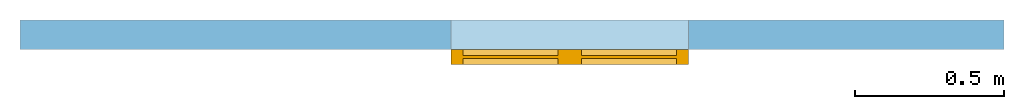
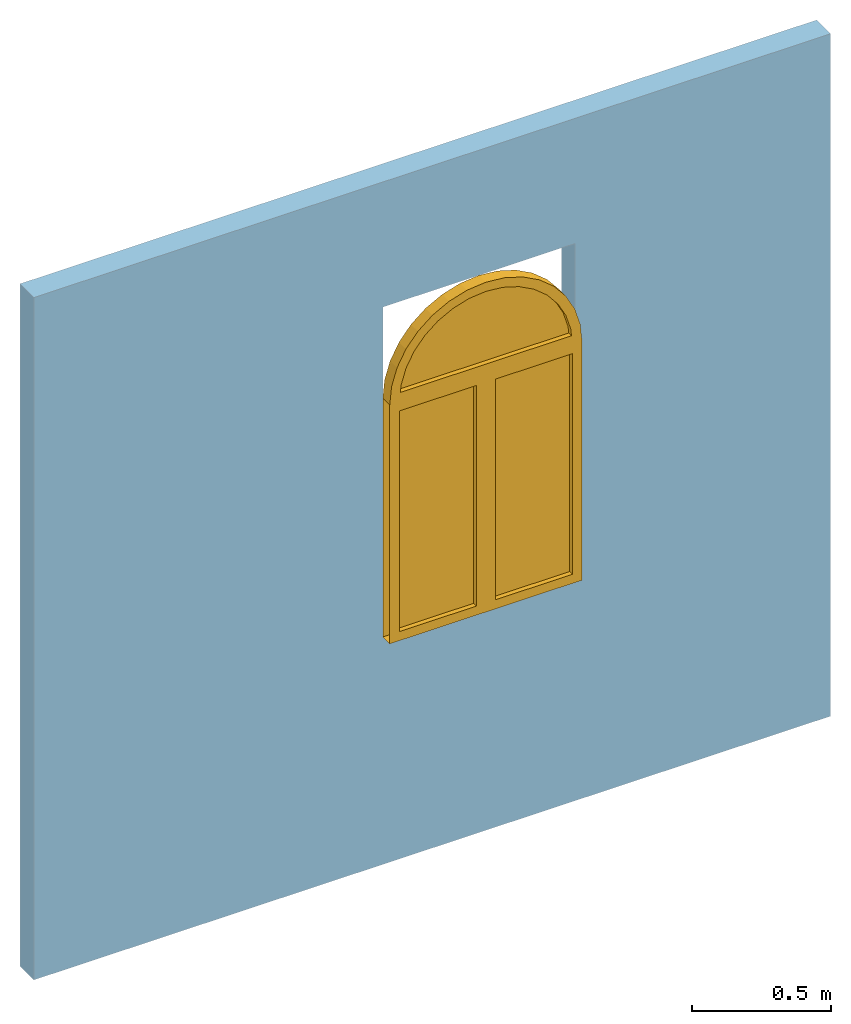
# One storey, part 2 of 2: 1 window, 1 opening, plus 1 element that does not belong to this part.
"""IFC4 building model written with IfcOpenShell, lengths in metres."""

from ifc_helpers import new_model, entity, si_unit, converted_unit, frame, origin_with_axes, origin_2d_with_axis, place, context, subcontext, project, spatial, line, indexed_curve, outline, extrude, polygons, source, transform, mapped, material, layer, layer_set, layer_usage, type_object, type_shapes, element, fill, save


model = new_model("IFC4")

# Units and contexts
model_context = context("Model", 3, precision=1e-05, world=origin_with_axes())
plan_context = context("Plan", 2, precision=1e-05, world=origin_2d_with_axis())
body_context = subcontext(model_context, "Body", "Model", "MODEL_VIEW")
ifc_project = project(units=[converted_unit("PLANEANGLEUNIT", "degree", entity("IfcReal", 0.0174532925199433), si_unit("PLANEANGLEUNIT", "RADIAN"), dimensions=[0, 0, 0, 0, 0, 0, 0]), si_unit("AREAUNIT", "SQUARE_METRE"), si_unit("VOLUMEUNIT", "CUBIC_METRE"), si_unit("LENGTHUNIT", "METRE")], contexts=[model_context, plan_context])

# Site, building, storey
site_placement = place(None, origin_with_axes())
site = spatial("IfcSite", under=ifc_project, at=site_placement)
building_placement = place(site_placement, origin_with_axes())
building = spatial("IfcBuilding", under=site, at=building_placement, Name="Building")
storey_placement = place(building_placement, origin_with_axes())
storey = spatial("IfcBuildingStorey", under=building, at=storey_placement, Name="Storey")

# Wall, opening, window
ifc_material = material()
ifc_layer = layer(ifc_material, 0.1)
ifc_layer_set = layer_set([ifc_layer])
ifc_layer_usage = layer_usage(ifc_layer_set, "AXIS2", "POSITIVE", 0.0)
wall_type = type_object("IfcWallType", PredefinedType="SOLIDWALL", material=ifc_layer_set)
wall_placement = place(storey_placement, origin_with_axes())
wall = element("IfcWall", 1, at=wall_placement, inside=storey, type_object=wall_type, material=ifc_layer_usage, Name="Wall", context=body_context, shape_type="SweptSolid", body=[
    extrude(outline(indexed_curve([(0.0, 0.0), (0.0, 0.1), (3.31257111095178, 0.1), (3.31257111095178, 0.0), (0.0, 0.0)], self_intersect=False)), origin_with_axes(), (0.0, 0.0, 1.0), 3.0),
])
shared_shape_1 = source(origin_with_axes(), body_context, "Body", "SweptSolid", [
    extrude(outline(indexed_curve([(0.0, 0.0), (0.799999833106995, 0.0), (0.799999833106995, 1.44999992847443), (0.0, 1.44999992847443)], segments=[line(1, 2, 3, 4, 1)])), frame((-8.94069671630859e-08, -0.600000023841858, 1.19209289550781e-07), z_axis=(0.0, -1.0, 0.0), x_axis=(1.0, 0.0, 0.0)), (0.0, 0.0, -1.0), 1.2),
])
opening_placement = place(wall_placement, frame((1.45082700252533, 0.0, 1.0), z_axis=(0.0, 0.0, 1.0), x_axis=(1.0, 0.0, 0.0)))
opening = element("IfcOpeningElement", 2, at=opening_placement, cuts=wall, Name="Opening", PredefinedType="OPENING", context=body_context, shape_type="MappedRepresentation", body=[
    mapped(shared_shape_1, transform((0.0, 0.0, 0.0), x_axis=(1.0, 0.0, 0.0), y_axis=(0.0, 1.0, 0.0), z_axis=(0.0, 0.0, 1.0), scale=1.0)),
])
window_type = type_object("IfcWindowType", Name="Window", PartitioningType="NOTDEFINED", PredefinedType="WINDOW")
shared_shape_2 = source(origin_with_axes(), body_context, "Body", "Tessellation", [
    polygons([(0.359999895095825, -0.0299999713897705, 1.01000022888184), (0.0399999916553497, -0.0299999713897705, 1.01000022888184), (0.0399999916553497, -0.0299999713897705, 0.0400000810623169), (0.359999895095825, -0.0299999713897705, 0.0400000810623169), (0.359999895095825, -0.0499999523162842, 1.01000022888184), (0.359999895095825, -0.0499999523162842, 0.0400002002716064), (2.98023223876953e-08, -0.0499999523162842, 1.19209289550781e-07), (2.98023223876953e-08, -0.0249999761581421, 1.19209289550781e-07), (0.399999856948853, -0.0249999761581421, 1.19209289550781e-07), (0.399999856948853, -0.0499999523162842, 1.19209289550781e-07), (0.0399999916553497, -0.0499999523162842, 1.01000022888184), (0.0399999916553497, -0.0499999523162842, 0.0400002002716064), (2.98023223876953e-08, -0.0499999523162842, 1.05000019073486), (0.399999856948853, -0.0499999523162842, 1.05000019073486), (0.399999856948853, -0.0249999761581421, 1.05000019073486), (0.359999895095825, -0.0199999809265137, 1.01000022888184), (0.0399999916553497, -0.0199999809265137, 1.01000022888184), (0.0399999916553497, -0.0199999809265137, 0.0400000810623169), (0.359999895095825, -0.0199999809265137, 0.0400000810623169), (0.359999895095825, 0.0, 1.01000022888184), (0.359999895095825, 0.0, 0.0400000810623169), (2.98023223876953e-08, 0.0, 1.19209289550781e-07), (0.399999856948853, 0.0, 1.19209289550781e-07), (0.0399999916553497, 0.0, 1.01000022888184), (0.0399999916553497, 0.0, 0.0400000810623169), (2.98023223876953e-08, 0.0, 1.05000019073486), (0.399999856948853, 0.0, 1.05000019073486), (0.0675821602344513, -0.0299999713897705, 1.18769216537476), (0.0471070110797882, -0.0299999713897705, 1.12019467353821), (0.0441330969333649, -0.0299999713897705, 1.09000015258789), (0.399999856948853, -0.0299999713897705, 1.09000015258789), (0.755866527557373, -0.0299999713897705, 1.09000015258789), (0.752892732620239, -0.0299999713897705, 1.12019515037537), (0.732417583465576, -0.0299999713897705, 1.18769216537476), (0.699167728424072, -0.0299999713897705, 1.24989795684814), (0.654421329498291, -0.0299999713897705, 1.3044216632843), (0.599897384643555, -0.0299999713897705, 1.34916830062866), (0.537691831588745, -0.0299999713897705, 1.38241791725159), (0.470194578170776, -0.0299999713897705, 1.40289306640625), (0.399999737739563, -0.0299999713897705, 1.40980648994446), (0.329805135726929, -0.0299999713897705, 1.40289306640625), (0.26230776309967, -0.0299999713897705, 1.38241791725159), (0.200102105736732, -0.0299999713897705, 1.34916830062866), (0.145578294992447, -0.0299999713897705, 1.3044216632843), (0.100831776857376, -0.0299999713897705, 1.24989771842957), (0.200102105736732, -0.0499999523162842, 1.34916830062866), (0.26230776309967, -0.0499999523162842, 1.38241791725159), (0.399999737739563, -0.0499999523162842, 1.45000004768372), (0.399999737739563, -0.0249999761581421, 1.45000004768372), (0.321963787078857, -0.0249999761581421, 1.44231414794922), (0.321963787078857, -0.0499999523162842, 1.44231414794922), (0.792313814163208, -0.0499999523162842, 1.12803649902344), (0.792313814163208, -0.0249999761581421, 1.12803649902344), (0.769551515579224, -0.0249999761581421, 1.20307350158691), (0.769551515579224, -0.0499999523162842, 1.20307350158691), (0.329805135726929, -0.0499999523162842, 1.40289306640625), (0.0304481089115143, -0.0499999523162842, 1.20307350158691), (0.0304481089115143, -0.0249999761581421, 1.20307350158691), (0.00768569111824036, -0.0249999761581421, 1.12803602218628), (0.00768569111824036, -0.0499999523162842, 1.12803602218628), (0.399999737739563, -0.0499999523162842, 1.40980648994446), (0.478035926818848, -0.0499999523162842, 1.44231414794922), (0.478035926818848, -0.0249999761581421, 1.44231414794922), (0.799999713897705, -0.0499999523162842, 1.05000019073486), (0.799999713897705, -0.0249999761581421, 1.05000019073486), (0.470194578170776, -0.0499999523162842, 1.40289306640625), (0.0674120485782623, -0.0499999523162842, 1.27222800254822), (0.0674120485782623, -0.0249999761581421, 1.27222800254822), (0.537691831588745, -0.0499999523162842, 1.38241791725159), (0.553073167800903, -0.0499999523162842, 1.41955184936523), (0.553073167800903, -0.0249999761581421, 1.41955184936523), (0.599897384643555, -0.0499999523162842, 1.34916830062866), (0.117157131433487, -0.0499999523162842, 1.33284282684326), (0.117157131433487, -0.0249999761581421, 1.33284282684326), (0.654421329498291, -0.0499999523162842, 1.3044216632843), (0.622227668762207, -0.0499999523162842, 1.38258790969849), (0.622227668762207, -0.0249999761581421, 1.38258790969849), (0.699167728424072, -0.0499999523162842, 1.24989795684814), (0.17777182161808, -0.0499999523162842, 1.38258790969849), (0.17777182161808, -0.0249999761581421, 1.38258790969849), (0.0471070110797882, -0.0499999523162842, 1.12019467353821), (0.0441330969333649, -0.0499999523162842, 1.09000015258789), (0.399999856948853, -0.0499999523162842, 1.09000015258789), (0.755866527557373, -0.0499999523162842, 1.09000015258789), (0.752892732620239, -0.0499999523162842, 1.12019515037537), (0.732417583465576, -0.0499999523162842, 1.18769216537476), (0.732587575912476, -0.0499999523162842, 1.2722282409668), (0.682842493057251, -0.0499999523162842, 1.33284282684326), (0.246926322579384, -0.0499999523162842, 1.41955184936523), (0.145578294992447, -0.0499999523162842, 1.3044216632843), (0.100831776857376, -0.0499999523162842, 1.24989771842957), (0.0675821602344513, -0.0499999523162842, 1.18769216537476), (0.732587575912476, -0.0249999761581421, 1.2722282409668), (0.246926322579384, -0.0249999761581421, 1.41955184936523), (0.682842493057251, -0.0249999761581421, 1.33284282684326), (-8.94069671630859e-08, -0.0249999761581421, 1.05000019073486), (0.0675821602344513, -0.0199999809265137, 1.18769216537476), (0.0471070110797882, -0.0199999809265137, 1.12019467353821), (0.0441330969333649, -0.0199999809265137, 1.09000015258789), (0.399999856948853, -0.0199999809265137, 1.09000015258789), (0.755866527557373, -0.0199999809265137, 1.09000015258789), (0.752892732620239, -0.0199999809265137, 1.12019515037537), (0.732417583465576, -0.0199999809265137, 1.18769216537476), (0.699167728424072, -0.0199999809265137, 1.24989795684814), (0.654421329498291, -0.0200001001358032, 1.3044216632843), (0.599897384643555, -0.0200001001358032, 1.34916830062866), (0.537691831588745, -0.0200001001358032, 1.38241791725159), (0.470194578170776, -0.0200001001358032, 1.40289306640625), (0.399999737739563, -0.0200001001358032, 1.40980648994446), (0.329805135726929, -0.0200001001358032, 1.40289306640625), (0.26230776309967, -0.0200001001358032, 1.38241791725159), (0.200102105736732, -0.0200001001358032, 1.34916830062866), (0.145578294992447, -0.0200001001358032, 1.3044216632843), (0.100831776857376, -0.0199999809265137, 1.24989771842957), (0.200102105736732, -1.19209289550781e-07, 1.34916830062866), (0.26230776309967, -1.19209289550781e-07, 1.38241791725159), (0.399999737739563, -1.19209289550781e-07, 1.45000004768372), (0.321963787078857, -1.19209289550781e-07, 1.44231414794922), (0.792313814163208, 0.0, 1.12803649902344), (0.769551515579224, 0.0, 1.20307350158691), (0.329805135726929, -1.19209289550781e-07, 1.40289306640625), (0.0304481089115143, 0.0, 1.20307350158691), (0.00768569111824036, 0.0, 1.12803602218628), (0.399999737739563, -1.19209289550781e-07, 1.40980648994446), (0.478035926818848, -1.19209289550781e-07, 1.44231414794922), (0.799999713897705, 0.0, 1.05000019073486), (0.470194578170776, -1.19209289550781e-07, 1.40289306640625), (0.0674120485782623, 0.0, 1.27222800254822), (0.537691831588745, -1.19209289550781e-07, 1.38241791725159), (0.553073167800903, -1.19209289550781e-07, 1.41955184936523), (0.599897384643555, -1.19209289550781e-07, 1.34916830062866), (0.117157131433487, -1.19209289550781e-07, 1.33284282684326), (0.654421329498291, -1.19209289550781e-07, 1.3044216632843), (0.622227668762207, -1.19209289550781e-07, 1.38258790969849), (0.699167728424072, 0.0, 1.24989795684814), (0.17777182161808, -1.19209289550781e-07, 1.38258790969849), (0.0471070110797882, 0.0, 1.12019467353821), (0.0441330969333649, 0.0, 1.09000015258789), (0.399999856948853, 0.0, 1.09000015258789), (0.755866527557373, 0.0, 1.09000015258789), (0.752892732620239, 0.0, 1.12019515037537), (0.732417583465576, 0.0, 1.18769216537476), (0.732587575912476, 0.0, 1.2722282409668), (0.682842493057251, -1.19209289550781e-07, 1.33284282684326), (0.246926322579384, -1.19209289550781e-07, 1.41955184936523), (0.145578294992447, -1.19209289550781e-07, 1.3044216632843), (0.100831776857376, 0.0, 1.24989771842957), (0.0675821602344513, 0.0, 1.18769216537476), (0.759999513626099, -0.0299999713897705, 1.01000022888184), (0.439999580383301, -0.0299999713897705, 1.01000022888184), (0.439999580383301, -0.0299999713897705, 0.0400000810623169), (0.759999513626099, -0.0299999713897705, 0.0400000810623169), (0.759999513626099, -0.0499999523162842, 1.01000022888184), (0.759999513626099, -0.0499999523162842, 0.0400002002716064), (0.799999475479126, -0.0249999761581421, 1.19209289550781e-07), (0.799999475479126, -0.0499999523162842, 1.19209289550781e-07), (0.439999580383301, -0.0499999523162842, 1.01000022888184), (0.439999580383301, -0.0499999523162842, 0.0400002002716064), (0.759999513626099, -0.0199999809265137, 1.01000022888184), (0.439999580383301, -0.0199999809265137, 1.01000022888184), (0.439999580383301, -0.0199999809265137, 0.0400000810623169), (0.759999513626099, -0.0199999809265137, 0.0400000810623169), (0.759999513626099, 0.0, 1.01000022888184), (0.759999513626099, 0.0, 0.0400000810623169), (0.799999475479126, 0.0, 1.19209289550781e-07), (0.439999580383301, 0.0, 1.01000022888184), (0.439999580383301, 0.0, 0.0400000810623169)], [[[1, 4, 6, 5]], [[10, 7, 8, 9]], [[5, 11, 2, 1]], [[11, 12, 3, 2]], [[7, 12, 11, 13]], [[10, 6, 12, 7]], [[5, 6, 10, 14]], [[14, 13, 11, 5]], [[9, 15, 14, 10]], [[3, 12, 6, 4]], [[17, 18, 19, 16]], [[21, 20, 16, 19]], [[8, 9, 23, 22]], [[17, 16, 20, 24]], [[24, 25, 18, 17]], [[22, 25, 24, 26]], [[23, 21, 25, 22]], [[20, 21, 23, 27]], [[27, 26, 24, 20]], [[27, 23, 9, 15]], [[19, 18, 25, 21]], [[38, 39, 40, 41, 42, 43, 44, 45, 28, 29, 30, 31, 32, 33, 34, 35, 36, 37]], [[47, 46, 43, 42]], [[51, 48, 49, 50]], [[53, 54, 55, 52]], [[56, 47, 42, 41]], [[58, 59, 60, 57]], [[61, 56, 41, 40]], [[48, 62, 63, 49]], [[65, 53, 52, 64]], [[66, 61, 40, 39]], [[68, 58, 57, 67]], [[69, 66, 39, 38]], [[62, 70, 71, 63]], [[72, 69, 38, 37]], [[74, 68, 67, 73]], [[75, 72, 37, 36]], [[70, 76, 77, 71]], [[36, 35, 78, 75]], [[73, 79, 80, 74]], [[60, 13, 82, 81]], [[14, 83, 82, 13]], [[64, 84, 83, 14]], [[64, 52, 85, 84]], [[52, 55, 86, 85]], [[55, 87, 78, 86]], [[87, 88, 75, 78]], [[76, 72, 75, 88]], [[72, 76, 70, 69]], [[69, 70, 62, 66]], [[48, 61, 66, 62]], [[61, 48, 51, 56]], [[56, 51, 89, 47]], [[47, 89, 79, 46]], [[46, 79, 73, 90]], [[91, 90, 73, 67]], [[67, 57, 92, 91]], [[57, 60, 81, 92]], [[46, 90, 44, 43]], [[54, 93, 87, 55]], [[30, 29, 81, 82]], [[89, 51, 50, 94]], [[45, 44, 90, 91]], [[28, 45, 91, 92]], [[93, 95, 88, 87]], [[33, 32, 84, 85]], [[82, 83, 31, 30]], [[79, 89, 94, 80]], [[29, 28, 92, 81]], [[34, 33, 85, 86]], [[83, 84, 32, 31]], [[76, 88, 95, 77]], [[35, 34, 86, 78]], [[59, 96, 13, 60]], [[107, 108, 109, 110, 111, 112, 113, 114, 97, 98, 99, 100, 101, 102, 103, 104, 105, 106]], [[112, 111, 116, 115]], [[49, 50, 118, 117]], [[120, 119, 53, 54]], [[111, 110, 121, 116]], [[123, 122, 58, 59]], [[110, 109, 124, 121]], [[63, 49, 117, 125]], [[119, 126, 65, 53]], [[109, 108, 127, 124]], [[122, 128, 68, 58]], [[108, 107, 129, 127]], [[71, 63, 125, 130]], [[107, 106, 131, 129]], [[74, 68, 128, 132]], [[106, 105, 133, 131]], [[77, 71, 130, 134]], [[105, 104, 135, 133]], [[80, 74, 132, 136]], [[123, 26, 138, 137]], [[27, 139, 138, 26]], [[126, 140, 139, 27]], [[126, 119, 141, 140]], [[119, 120, 142, 141]], [[120, 143, 135, 142]], [[143, 144, 133, 135]], [[134, 131, 133, 144]], [[131, 134, 130, 129]], [[129, 130, 125, 127]], [[117, 124, 127, 125]], [[124, 117, 118, 121]], [[121, 118, 145, 116]], [[116, 145, 136, 115]], [[115, 136, 132, 146]], [[147, 146, 132, 128]], [[128, 122, 148, 147]], [[122, 123, 137, 148]], [[113, 112, 115, 146]], [[143, 120, 54, 93]], [[137, 138, 99, 98]], [[50, 94, 145, 118]], [[146, 147, 114, 113]], [[147, 148, 97, 114]], [[144, 143, 93, 95]], [[140, 141, 102, 101]], [[100, 99, 138, 139]], [[94, 80, 136, 145]], [[148, 137, 98, 97]], [[141, 142, 103, 102]], [[101, 100, 139, 140]], [[95, 77, 134, 144]], [[142, 135, 104, 103]], [[26, 123, 59, 96]], [[150, 151, 152, 149]], [[149, 152, 154, 153]], [[156, 10, 9, 155]], [[153, 157, 150, 149]], [[157, 158, 151, 150]], [[10, 158, 157, 14]], [[156, 154, 158, 10]], [[64, 153, 154, 156]], [[64, 14, 157, 153]], [[155, 65, 64, 156]], [[151, 158, 154, 152]], [[160, 161, 162, 159]], [[164, 163, 159, 162]], [[9, 155, 165, 23]], [[160, 159, 163, 166]], [[166, 167, 161, 160]], [[23, 167, 166, 27]], [[165, 164, 167, 23]], [[126, 163, 164, 165]], [[126, 27, 166, 163]], [[126, 165, 155, 65]], [[162, 161, 167, 164]], [[2, 3, 4, 1]]], closed=False),
])
type_shapes(window_type, [shared_shape_2])
window_placement = place(opening_placement, origin_with_axes())
window = element("IfcWindow", 3, at=window_placement, inside=storey, type_object=window_type, Name="Window", context=body_context, shape_type="MappedRepresentation", body=[
    mapped(shared_shape_2, transform((0.0, 0.0, 0.0), x_axis=(1.0, 0.0, 0.0), y_axis=(0.0, 1.0, 0.0), z_axis=(0.0, 0.0, 1.0), scale=1.0)),
])
fill(opening, window)

save(model, "model.ifc")
